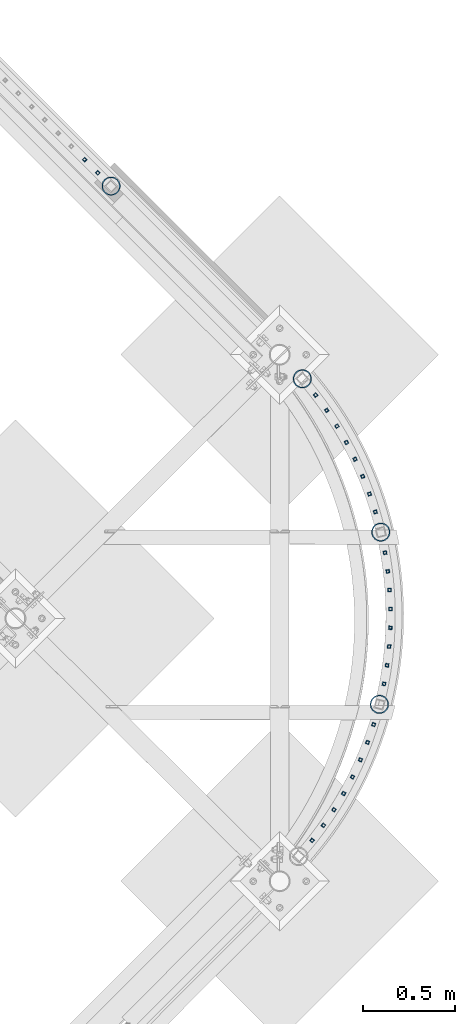
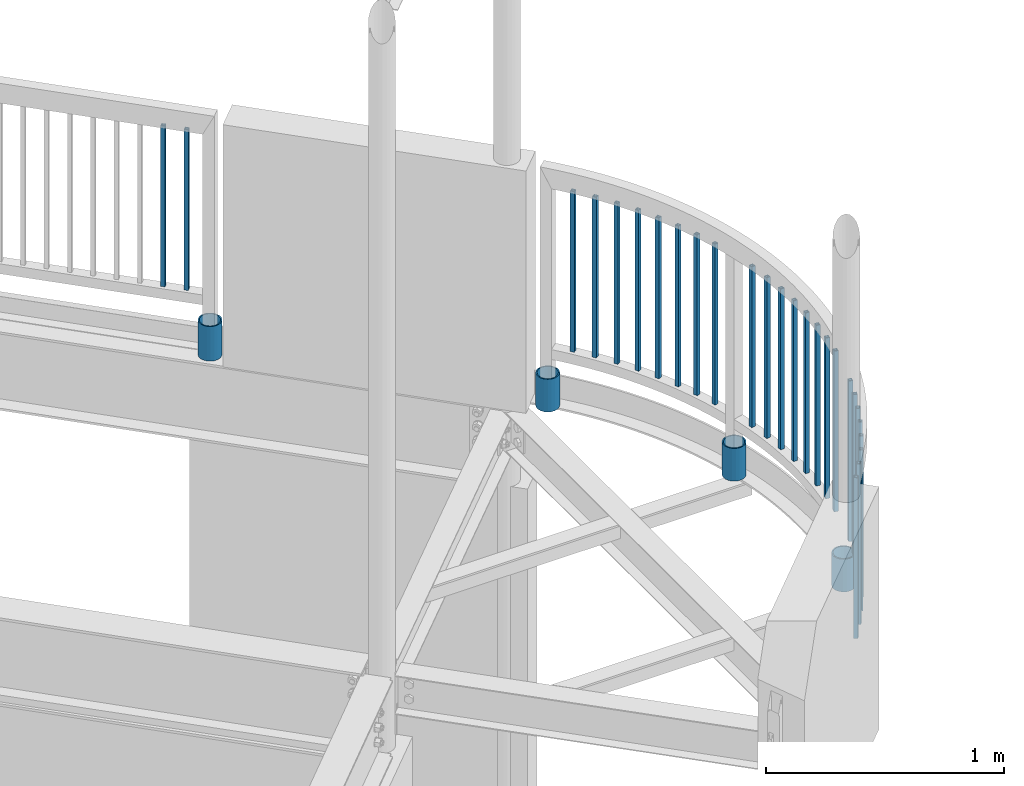
# One storey, part 277 of 975: 30 columns.
"""IFC2X3 building model written with IfcOpenShell, lengths in millimetres."""

from ifc_helpers import new_model, si_unit, frame, origin_with_axes, place, context, subcontext, project, spatial, faceted_brep, material, type_object, element, save


model = new_model("IFC2X3")

# Units and contexts
model_context = context("Model", 3, precision=1e-05, world=origin_with_axes())
body_context = subcontext(model_context, "Body", "Model", "MODEL_VIEW")
ifc_project = project(units=[si_unit("LENGTHUNIT", "METRE", prefix="MILLI"), si_unit("AREAUNIT", "SQUARE_METRE"), si_unit("VOLUMEUNIT", "CUBIC_METRE"), si_unit("MASSUNIT", "GRAM", prefix="KILO"), si_unit("TIMEUNIT", "SECOND"), si_unit("PLANEANGLEUNIT", "RADIAN"), si_unit("SOLIDANGLEUNIT", "STERADIAN"), si_unit("THERMODYNAMICTEMPERATUREUNIT", "DEGREE_CELSIUS"), si_unit("LUMINOUSINTENSITYUNIT", "LUMEN")], contexts=[model_context])

# Site, building, storey
site_placement = place(None, origin_with_axes())
site = spatial("IfcSite", under=ifc_project, at=site_placement, CompositionType="ELEMENT")
building_placement = place(site_placement, origin_with_axes())
building = spatial("IfcBuilding", under=site, at=building_placement, Name="Undefined", CompositionType="ELEMENT")
storey_placement = place(building_placement, origin_with_axes())
storey = spatial("IfcBuildingStorey", under=building, at=storey_placement, Name="Undefined", CompositionType="ELEMENT", Elevation=0.0)

# Columns
ifc_material_1 = material()
column_type_1 = type_object("IfcColumnType", Name="HSS3/4X3/4X.120_TUBES", PredefinedType="NOTDEFINED")
for number, where, z_axis, x_axis, name in (
    (1, (36056.6912059696, 12244.4893674589, 4254.49994796637), (-0.283882476097402, 0.958859082328998, -1.36006965476554e-08), (0.0, 0.0, 1.0), "PICKET"),
    (2, (35732.4870797889, 12877.9863255874, 4254.49994796637), (-0.607293483116321, 0.794477580152169, -1.34104184326134e-08), (0.0, 0.0, 1.0), "PICKET"),
    (3, (35792.6550644485, 12795.3541853441, 4254.49994796637), (-0.56508307472927, 0.825034010604723, -1.3596040844277e-08), (0.0, 0.0, 1.0), "PICKET"),
    (4, (35848.4368898386, 12709.6999680789, 4254.49994796637), (-0.521338232018431, 0.853350132030163, -1.44109080792987e-08), (0.0, 0.0, 1.0), "PICKET"),
    (5, (35899.681085213, 12621.2562604475, 4254.49994796637), (-0.476177741822168, 0.879349053671601, -1.38854329634341e-08), (0.0, 0.0, 1.0), "PICKET"),
    (6, (35946.2485013691, 12530.2632237265, 4254.49994796637), (-0.429724229889405, 0.902960179767612, -1.34138672365225e-08), (0.0, 0.0, 1.0), "PICKET"),
    (7, (35988.0126884958, 12436.9679416766, 4254.49994796637), (-0.382103840208313, 0.924119394503794, -1.43061743074213e-08), (0.0, 0.0, 1.0), "PICKET"),
    (8, (36024.8602395373, 12341.6237496071, 4254.49994796637), (-0.333445879927349, 0.942769242794585, -1.29804593598237e-08), (0.0, 0.0, 1.0), "PICKET"),
    (9, (36103.5076687763, 11311.4462285557, 4254.49994796637), (0.191835812975776, 0.981427032876068, -1.31422229969758e-08), (0.0, 0.0, 1.0), "PICKET"),
    (10, (36109.0972812196, 12023.0609189764, 4254.49994796637), (-0.170932835042666, 0.985282683245918, -1.33214734887588e-08), (0.0, 0.0, 1.0), "PICKET"),
    (11, (36124.2199175269, 11921.9690654457, 4254.49994796637), (-0.119375467966675, 0.992849181722852, -1.31457900351961e-08), (0.0, 0.0, 1.0), "PICKET"),
    (12, (36134.0559506074, 11820.2266975139, 4254.49994796637), (-0.0674939469756137, 0.997719683639474, -1.40355705298134e-08), (0.0, 0.0, 1.0), "PICKET"),
    (13, (36138.5786715598, 11718.1100878252, 4254.49994796637), (-0.0154291539925689, 0.999880963518695, -1.4013763575349e-08), (0.0, 0.0, 1.0), "PICKET"),
    (14, (36137.7757993245, 11615.8965252451, 4254.49994796637), (0.036677537990523, 0.99932715274176, -1.29912523334497e-08), (0.0, 0.0, 1.0), "PICKET"),
    (15, (36131.6495140321, 11513.8635619066, 4254.49994796637), (0.0886846340071643, 0.996059755080495, -1.40335214382503e-08), (0.0, 0.0, 1.0), "PICKET"),
    (16, (36120.216451083, 11412.2882595406, 4254.49994796637), (0.140450914975729, 0.990087642828896, -1.3011589544476e-08), (0.0, 0.0, 1.0), "PICKET"),
    (17, (35713.4324205708, 10462.563089986, 4254.49994796637), (0.624042439778597, 0.781390448722773, -1.35876362037379e-08), (0.0, 0.0, 1.0), "PICKET"),
    (18, (36047.5479517224, 11090.8890589191, 4254.49994796637), (0.304198321977405, 0.952608723929259, -1.32965087686898e-08), (0.0, 0.0, 1.0), "PICKET"),
    (19, (36014.1951655572, 10994.2668635693, 4254.49994796637), (0.353408549827145, 0.935469078542457, -1.35747304739198e-08), (0.0, 0.0, 1.0), "PICKET"),
    (20, (35975.8544247656, 10899.5132642987, 4254.49994796637), (0.401659127155996, 0.91578924735568, -1.3913554539613e-08), (0.0, 0.0, 1.0), "PICKET"),
    (21, (35932.6298403295, 10806.8855563517, 4254.49994796637), (0.448819032838204, 0.893622669677856, -1.43100078275893e-08), (0.0, 0.0, 1.0), "PICKET"),
    (22, (35884.6387848882, 10716.6352622978, 4254.49994796637), (0.494760210039676, 0.869029536069687, -1.33969151647761e-08), (0.0, 0.0, 1.0), "PICKET"),
    (23, (35832.0115740227, 10629.0074490436, 4254.49994796637), (0.539357907906692, 0.842076627854328, -1.38804252856062e-08), (0.0, 0.0, 1.0), "PICKET"),
    (24, (35774.891112395, 10544.240062375, 4254.49994796637), (0.582491025955096, 0.812837132937331, -1.30186463138671e-08), (0.0, 0.0, 1.0), "PICKET"),
    (25, (34479.1391914805, 14155.1566726498, 4254.49994796637), (-0.707106781186601, 0.707106781186494, 2.36468622460961e-14), (0.0, 0.0, 1.0), "PICKET"),
    (26, (34550.9735664805, 14083.3222976498, 4254.49994796637), (-0.707106781186601, 0.707106781186494, 2.36468622460961e-14), (0.0, 0.0, 1.0), "PICKET"),
):
    element("IfcColumn", number, at=place(storey_placement, frame(where, z_axis=z_axis, x_axis=x_axis)), inside=storey, type_object=column_type_1, material=ifc_material_1, Name=name, ObjectType="HSS3/4X3/4X.120_TUBES", context=body_context, shape_type="Brep", body=[
        faceted_brep([(0.0, 6.34999999998763, -6.34999999998763), (0.0, -6.35000000000582, -6.34999999998763), (825.49997943247, -6.35000000000582, -6.34999999998763), (825.49997943247, 6.34999999998763, -6.34999999998763), (0.0, -6.34999999998763, 6.34999999998763), (825.49997943247, -6.34999999998763, 6.34999999998763), (0.0, 6.35000000000946, 6.34999999998763), (825.49997943247, 6.35000000000946, 6.34999999998763), (0.0, 9.52499999997963, -9.52499999997963), (0.0, 9.52500000000873, 9.5249999999869), (825.49997943247, 9.52500000000873, 9.5249999999869), (825.49997943247, 9.52499999997963, -9.52499999997963), (0.0, -9.52499999997963, 9.52499999998327), (825.49997943247, -9.52499999997963, 9.52499999998327), (0.0, -9.52500000000873, -9.5249999999869), (825.49997943247, -9.52500000000873, -9.5249999999869)], [[[0, 1, 2, 3]], [[1, 4, 5, 2]], [[4, 6, 7, 5]], [[6, 0, 3, 7]], [[8, 9, 10, 11]], [[9, 12, 13, 10]], [[12, 14, 15, 13]], [[14, 8, 11, 15]], [[13, 15, 11, 10], [5, 7, 3, 2]], [[14, 12, 9, 8], [6, 4, 1, 0]]]),
    ])
ifc_material_2 = material(Name="STEEL/A53")
column_type_2 = type_object("IfcColumnType", Name="PIPE3-1/2STD", PredefinedType="NOTDEFINED")
column_1_placement = place(storey_placement, frame((36078.7761034097, 11200.4077223262, 3946.52499999334), z_axis=(0.969531343145851, -0.244967293036851, 0.0), x_axis=(0.0, 0.0, 1.0)))
element("IfcColumn", 27, at=column_1_placement, inside=storey, type_object=column_type_2, material=ifc_material_2, ObjectType="PIPE3-1/2STD", context=body_context, shape_type="Brep", body=[
    faceted_brep([(0.0, -45.0595999999932, 1.45519152283669e-11), (0.0, -42.8542262016344, 13.924182159768), (168.275, -42.8542262015544, 13.9241821597034), (168.275, -45.0595999998914, 2.72848410531878e-12), (0.0, -36.45398215971, 26.4853683542424), (168.275, -36.4539821596554, 26.485368354136), (0.0, -26.4853683541623, 36.45398215979), (168.275, -26.4853683541369, 36.4539821596509), (0.0, -13.9241821596988, 42.8542262017108), (168.275, -13.9241821597025, 42.8542262015517), (0.0, 3.63797880709171e-11, 45.0596000000514), (168.275, 0.0, 45.0595999998905), (0.0, 13.9241821597716, 42.8542262017036), (168.275, 13.9241821597025, 42.8542262015517), (0.0, 26.4853683542242, 36.4539821597718), (168.275, 26.4853683541296, 36.4539821596509), (0.0, 36.4539821597537, 26.4853683542206), (168.275, 36.4539821596481, 26.4853683541342), (0.0, 42.8542262016563, 13.9241821597425), (168.275, 42.8542262015471, 13.9241821597034), (0.0, 45.0595999999932, -1.09139364212751e-11), (168.275, 45.0595999998914, -9.09494701772928e-13), (0.0, 42.8542262016344, -13.9241821597643), (168.275, 42.8542262015471, -13.9241821596997), (0.0, 36.45398215971, -26.4853683542387), (168.275, 36.4539821596481, -26.4853683541323), (0.0, 26.4853683541623, -36.4539821597864), (168.275, 26.4853683541296, -36.4539821596472), (0.0, 13.9241821596988, -42.8542262017072), (168.275, 13.9241821596952, -42.854226201548), (0.0, -3.63797880709171e-11, -45.0596000000478), (168.275, 0.0, -45.0595999998886), (0.0, -13.9241821597716, -42.8542262016963), (168.275, -13.9241821597025, -42.8542262015499), (0.0, -26.4853683542242, -36.4539821597682), (168.275, -26.4853683541369, -36.4539821596472), (0.0, -36.4539821597537, -26.4853683542169), (168.275, -36.4539821596554, -26.4853683541305), (0.0, -42.8542262016563, -13.9241821597352), (168.275, -42.8542262015544, -13.9241821597016), (0.0, -50.799999999992, 1.81898940354586e-11), (0.0, -48.3136710278013, -15.6980633142484), (168.275, -48.3136710276813, -15.6980633142075), (168.275, -50.7999999998792, 9.09494701772928e-13), (0.0, -41.0980633142644, -29.8594908164741), (168.275, -41.0980633141517, -29.8594908163841), (0.0, -29.859490816485, -41.0980633142826), (168.275, -29.8594908163868, -41.0980633141471), (0.0, -15.6980633142848, -48.313671027845), (168.275, -15.6980633142084, -48.3136710276767), (0.0, -4.36557456851006e-11, -50.8000000000575), (168.275, 0.0, -50.7999999998747), (0.0, 15.6980633142011, -48.3136710278523), (168.275, 15.6980633142084, -48.3136710276749), (0.0, 29.8594908164159, -41.0980633143045), (168.275, 29.8594908163868, -41.0980633141471), (0.0, 41.0980633142135, -29.8594908165032), (168.275, 41.0980633141444, -29.8594908163859), (0.0, 48.3136710277722, -15.6980633142775), (168.275, 48.313671027674, -15.6980633142057), (0.0, 50.799999999992, -1.45519152283669e-11), (168.275, 50.7999999998719, 9.09494701772928e-13), (0.0, 48.313671027794, 15.6980633142521), (168.275, 48.313671027674, 15.6980633142093), (0.0, 41.0980633142644, 29.8594908164814), (168.275, 41.0980633141444, 29.8594908163877), (0.0, 29.859490816485, 41.0980633142863), (168.275, 29.8594908163795, 41.0980633141507), (0.0, 15.6980633142848, 48.3136710278486), (168.275, 15.6980633142084, 48.3136710276785), (0.0, 4.00177668780088e-11, 50.8000000000611), (168.275, 0.0, 50.7999999998765), (0.0, -15.6980633142011, 48.3136710278559), (168.275, -15.6980633142084, 48.3136710276785), (0.0, -29.8594908164159, 41.0980633143081), (168.275, -29.8594908163941, 41.0980633141507), (0.0, -41.0980633142171, 29.8594908165069), (168.275, -41.0980633141517, 29.8594908163896), (0.0, -48.3136710277722, 15.6980633142812), (168.275, -48.3136710276813, 15.6980633142093)], [[[0, 1, 2, 3]], [[1, 4, 5, 2]], [[4, 6, 7, 5]], [[6, 8, 9, 7]], [[8, 10, 11, 9]], [[10, 12, 13, 11]], [[12, 14, 15, 13]], [[14, 16, 17, 15]], [[16, 18, 19, 17]], [[18, 20, 21, 19]], [[20, 22, 23, 21]], [[22, 24, 25, 23]], [[24, 26, 27, 25]], [[26, 28, 29, 27]], [[28, 30, 31, 29]], [[30, 32, 33, 31]], [[32, 34, 35, 33]], [[34, 36, 37, 35]], [[36, 38, 39, 37]], [[38, 0, 3, 39]], [[40, 41, 42, 43]], [[41, 44, 45, 42]], [[44, 46, 47, 45]], [[46, 48, 49, 47]], [[48, 50, 51, 49]], [[50, 52, 53, 51]], [[52, 54, 55, 53]], [[54, 56, 57, 55]], [[56, 58, 59, 57]], [[58, 60, 61, 59]], [[60, 62, 63, 61]], [[62, 64, 65, 63]], [[64, 66, 67, 65]], [[66, 68, 69, 67]], [[68, 70, 71, 69]], [[70, 72, 73, 71]], [[72, 74, 75, 73]], [[74, 76, 77, 75]], [[76, 78, 79, 77]], [[78, 40, 43, 79]], [[45, 47, 49, 51, 53, 55, 57, 59, 61, 63, 65, 67, 69, 71, 73, 75, 77, 79, 43, 42], [5, 7, 9, 11, 13, 15, 17, 19, 21, 23, 25, 27, 29, 31, 33, 35, 37, 39, 3, 2]], [[78, 76, 74, 72, 70, 68, 66, 64, 62, 60, 58, 56, 54, 52, 50, 48, 46, 44, 41, 40], [38, 36, 34, 32, 30, 28, 26, 24, 22, 20, 18, 16, 14, 12, 10, 8, 6, 4, 1, 0]]]),
])
column_2_placement = place(storey_placement, frame((36086.125656387, 12134.6039135276, 3946.52499999334), z_axis=(0.968966441574155, 0.247192303891364, 0.0), x_axis=(0.0, 0.0, 1.0)))
element("IfcColumn", 28, at=column_2_placement, inside=storey, type_object=column_type_2, material=ifc_material_2, ObjectType="PIPE3-1/2STD", context=body_context, shape_type="Brep", body=[
    faceted_brep([(0.0, -45.0595999999932, 1.45519152283669e-11), (0.0, -42.8542262016344, 13.924182159768), (168.275, -42.8542262015544, 13.9241821597034), (168.275, -45.0595999998914, 2.72848410531878e-12), (0.0, -36.45398215971, 26.4853683542424), (168.275, -36.4539821596554, 26.485368354136), (0.0, -26.4853683541623, 36.45398215979), (168.275, -26.4853683541369, 36.4539821596509), (0.0, -13.9241821596988, 42.8542262017108), (168.275, -13.9241821597025, 42.8542262015517), (0.0, 3.63797880709171e-11, 45.0596000000514), (168.275, 0.0, 45.0595999998905), (0.0, 13.9241821597716, 42.8542262017036), (168.275, 13.9241821597025, 42.8542262015517), (0.0, 26.4853683542242, 36.4539821597718), (168.275, 26.4853683541296, 36.4539821596509), (0.0, 36.4539821597537, 26.4853683542206), (168.275, 36.4539821596481, 26.4853683541342), (0.0, 42.8542262016563, 13.9241821597425), (168.275, 42.8542262015471, 13.9241821597034), (0.0, 45.0595999999932, -1.09139364212751e-11), (168.275, 45.0595999998914, -9.09494701772928e-13), (0.0, 42.8542262016344, -13.9241821597643), (168.275, 42.8542262015471, -13.9241821596997), (0.0, 36.45398215971, -26.4853683542387), (168.275, 36.4539821596481, -26.4853683541323), (0.0, 26.4853683541623, -36.4539821597864), (168.275, 26.4853683541296, -36.4539821596472), (0.0, 13.9241821596988, -42.8542262017072), (168.275, 13.9241821596952, -42.854226201548), (0.0, -3.63797880709171e-11, -45.0596000000478), (168.275, 0.0, -45.0595999998886), (0.0, -13.9241821597716, -42.8542262016963), (168.275, -13.9241821597025, -42.8542262015499), (0.0, -26.4853683542242, -36.4539821597682), (168.275, -26.4853683541369, -36.4539821596472), (0.0, -36.4539821597537, -26.4853683542169), (168.275, -36.4539821596554, -26.4853683541305), (0.0, -42.8542262016563, -13.9241821597352), (168.275, -42.8542262015544, -13.9241821597016), (0.0, -50.799999999992, 1.81898940354586e-11), (0.0, -48.3136710278013, -15.6980633142484), (168.275, -48.3136710276813, -15.6980633142075), (168.275, -50.7999999998792, 9.09494701772928e-13), (0.0, -41.0980633142644, -29.8594908164741), (168.275, -41.0980633141517, -29.8594908163841), (0.0, -29.859490816485, -41.0980633142826), (168.275, -29.8594908163868, -41.0980633141471), (0.0, -15.6980633142848, -48.313671027845), (168.275, -15.6980633142084, -48.3136710276767), (0.0, -4.36557456851006e-11, -50.8000000000575), (168.275, 0.0, -50.7999999998747), (0.0, 15.6980633142011, -48.3136710278523), (168.275, 15.6980633142084, -48.3136710276749), (0.0, 29.8594908164159, -41.0980633143045), (168.275, 29.8594908163868, -41.0980633141471), (0.0, 41.0980633142135, -29.8594908165032), (168.275, 41.0980633141444, -29.8594908163859), (0.0, 48.3136710277722, -15.6980633142775), (168.275, 48.313671027674, -15.6980633142057), (0.0, 50.799999999992, -1.45519152283669e-11), (168.275, 50.7999999998719, 9.09494701772928e-13), (0.0, 48.313671027794, 15.6980633142521), (168.275, 48.313671027674, 15.6980633142093), (0.0, 41.0980633142644, 29.8594908164814), (168.275, 41.0980633141444, 29.8594908163877), (0.0, 29.859490816485, 41.0980633142863), (168.275, 29.8594908163795, 41.0980633141507), (0.0, 15.6980633142848, 48.3136710278486), (168.275, 15.6980633142084, 48.3136710276785), (0.0, 4.00177668780088e-11, 50.8000000000611), (168.275, 0.0, 50.7999999998765), (0.0, -15.6980633142011, 48.3136710278559), (168.275, -15.6980633142084, 48.3136710276785), (0.0, -29.8594908164159, 41.0980633143081), (168.275, -29.8594908163941, 41.0980633141507), (0.0, -41.0980633142171, 29.8594908165069), (168.275, -41.0980633141517, 29.8594908163896), (0.0, -48.3136710277722, 15.6980633142812), (168.275, -48.3136710276813, 15.6980633142093)], [[[0, 1, 2, 3]], [[1, 4, 5, 2]], [[4, 6, 7, 5]], [[6, 8, 9, 7]], [[8, 10, 11, 9]], [[10, 12, 13, 11]], [[12, 14, 15, 13]], [[14, 16, 17, 15]], [[16, 18, 19, 17]], [[18, 20, 21, 19]], [[20, 22, 23, 21]], [[22, 24, 25, 23]], [[24, 26, 27, 25]], [[26, 28, 29, 27]], [[28, 30, 31, 29]], [[30, 32, 33, 31]], [[32, 34, 35, 33]], [[34, 36, 37, 35]], [[36, 38, 39, 37]], [[38, 0, 3, 39]], [[40, 41, 42, 43]], [[41, 44, 45, 42]], [[44, 46, 47, 45]], [[46, 48, 49, 47]], [[48, 50, 51, 49]], [[50, 52, 53, 51]], [[52, 54, 55, 53]], [[54, 56, 57, 55]], [[56, 58, 59, 57]], [[58, 60, 61, 59]], [[60, 62, 63, 61]], [[62, 64, 65, 63]], [[64, 66, 67, 65]], [[66, 68, 69, 67]], [[68, 70, 71, 69]], [[70, 72, 73, 71]], [[72, 74, 75, 73]], [[74, 76, 77, 75]], [[76, 78, 79, 77]], [[78, 40, 43, 79]], [[45, 47, 49, 51, 53, 55, 57, 59, 61, 63, 65, 67, 69, 71, 73, 75, 77, 79, 43, 42], [5, 7, 9, 11, 13, 15, 17, 19, 21, 23, 25, 27, 29, 31, 33, 35, 37, 39, 3, 2]], [[78, 76, 74, 72, 70, 68, 66, 64, 62, 60, 58, 56, 54, 52, 50, 48, 46, 44, 41, 40], [38, 36, 34, 32, 30, 28, 26, 24, 22, 20, 18, 16, 14, 12, 10, 8, 6, 4, 1, 0]]]),
])
column_3_placement = place(storey_placement, frame((35660.5273593798, 12966.2522543199, 3946.52499999334), z_axis=(0.733697144241169, 0.679476637223351, 0.0), x_axis=(0.0, 0.0, 1.0)))
element("IfcColumn", 29, at=column_3_placement, inside=storey, type_object=column_type_2, material=ifc_material_2, ObjectType="PIPE3-1/2STD", context=body_context, shape_type="Brep", body=[
    faceted_brep([(0.0, -45.0595999999932, 1.45519152283669e-11), (0.0, -42.8542262016344, 13.924182159768), (168.275, -42.8542262015544, 13.9241821597034), (168.275, -45.0595999998914, 2.72848410531878e-12), (0.0, -36.45398215971, 26.4853683542424), (168.275, -36.4539821596554, 26.485368354136), (0.0, -26.4853683541623, 36.45398215979), (168.275, -26.4853683541369, 36.4539821596509), (0.0, -13.9241821596988, 42.8542262017108), (168.275, -13.9241821597025, 42.8542262015517), (0.0, 3.63797880709171e-11, 45.0596000000514), (168.275, 0.0, 45.0595999998905), (0.0, 13.9241821597716, 42.8542262017036), (168.275, 13.9241821597025, 42.8542262015517), (0.0, 26.4853683542242, 36.4539821597718), (168.275, 26.4853683541296, 36.4539821596509), (0.0, 36.4539821597537, 26.4853683542206), (168.275, 36.4539821596481, 26.4853683541342), (0.0, 42.8542262016563, 13.9241821597425), (168.275, 42.8542262015471, 13.9241821597034), (0.0, 45.0595999999932, -1.09139364212751e-11), (168.275, 45.0595999998914, -9.09494701772928e-13), (0.0, 42.8542262016344, -13.9241821597643), (168.275, 42.8542262015471, -13.9241821596997), (0.0, 36.45398215971, -26.4853683542387), (168.275, 36.4539821596481, -26.4853683541323), (0.0, 26.4853683541623, -36.4539821597864), (168.275, 26.4853683541296, -36.4539821596472), (0.0, 13.9241821596988, -42.8542262017072), (168.275, 13.9241821596952, -42.854226201548), (0.0, -3.63797880709171e-11, -45.0596000000478), (168.275, 0.0, -45.0595999998886), (0.0, -13.9241821597716, -42.8542262016963), (168.275, -13.9241821597025, -42.8542262015499), (0.0, -26.4853683542242, -36.4539821597682), (168.275, -26.4853683541369, -36.4539821596472), (0.0, -36.4539821597537, -26.4853683542169), (168.275, -36.4539821596554, -26.4853683541305), (0.0, -42.8542262016563, -13.9241821597352), (168.275, -42.8542262015544, -13.9241821597016), (0.0, -50.799999999992, 1.81898940354586e-11), (0.0, -48.3136710278013, -15.6980633142484), (168.275, -48.3136710276813, -15.6980633142075), (168.275, -50.7999999998792, 9.09494701772928e-13), (0.0, -41.0980633142644, -29.8594908164741), (168.275, -41.0980633141517, -29.8594908163841), (0.0, -29.859490816485, -41.0980633142826), (168.275, -29.8594908163868, -41.0980633141471), (0.0, -15.6980633142848, -48.313671027845), (168.275, -15.6980633142084, -48.3136710276767), (0.0, -4.36557456851006e-11, -50.8000000000575), (168.275, 0.0, -50.7999999998747), (0.0, 15.6980633142011, -48.3136710278523), (168.275, 15.6980633142084, -48.3136710276749), (0.0, 29.8594908164159, -41.0980633143045), (168.275, 29.8594908163868, -41.0980633141471), (0.0, 41.0980633142135, -29.8594908165032), (168.275, 41.0980633141444, -29.8594908163859), (0.0, 48.3136710277722, -15.6980633142775), (168.275, 48.313671027674, -15.6980633142057), (0.0, 50.799999999992, -1.45519152283669e-11), (168.275, 50.7999999998719, 9.09494701772928e-13), (0.0, 48.313671027794, 15.6980633142521), (168.275, 48.313671027674, 15.6980633142093), (0.0, 41.0980633142644, 29.8594908164814), (168.275, 41.0980633141444, 29.8594908163877), (0.0, 29.859490816485, 41.0980633142863), (168.275, 29.8594908163795, 41.0980633141507), (0.0, 15.6980633142848, 48.3136710278486), (168.275, 15.6980633142084, 48.3136710276785), (0.0, 4.00177668780088e-11, 50.8000000000611), (168.275, 0.0, 50.7999999998765), (0.0, -15.6980633142011, 48.3136710278559), (168.275, -15.6980633142084, 48.3136710276785), (0.0, -29.8594908164159, 41.0980633143081), (168.275, -29.8594908163941, 41.0980633141507), (0.0, -41.0980633142171, 29.8594908165069), (168.275, -41.0980633141517, 29.8594908163896), (0.0, -48.3136710277722, 15.6980633142812), (168.275, -48.3136710276813, 15.6980633142093)], [[[0, 1, 2, 3]], [[1, 4, 5, 2]], [[4, 6, 7, 5]], [[6, 8, 9, 7]], [[8, 10, 11, 9]], [[10, 12, 13, 11]], [[12, 14, 15, 13]], [[14, 16, 17, 15]], [[16, 18, 19, 17]], [[18, 20, 21, 19]], [[20, 22, 23, 21]], [[22, 24, 25, 23]], [[24, 26, 27, 25]], [[26, 28, 29, 27]], [[28, 30, 31, 29]], [[30, 32, 33, 31]], [[32, 34, 35, 33]], [[34, 36, 37, 35]], [[36, 38, 39, 37]], [[38, 0, 3, 39]], [[40, 41, 42, 43]], [[41, 44, 45, 42]], [[44, 46, 47, 45]], [[46, 48, 49, 47]], [[48, 50, 51, 49]], [[50, 52, 53, 51]], [[52, 54, 55, 53]], [[54, 56, 57, 55]], [[56, 58, 59, 57]], [[58, 60, 61, 59]], [[60, 62, 63, 61]], [[62, 64, 65, 63]], [[64, 66, 67, 65]], [[66, 68, 69, 67]], [[68, 70, 71, 69]], [[70, 72, 73, 71]], [[72, 74, 75, 73]], [[74, 76, 77, 75]], [[76, 78, 79, 77]], [[78, 40, 43, 79]], [[45, 47, 49, 51, 53, 55, 57, 59, 61, 63, 65, 67, 69, 71, 73, 75, 77, 79, 43, 42], [5, 7, 9, 11, 13, 15, 17, 19, 21, 23, 25, 27, 29, 31, 33, 35, 37, 39, 3, 2]], [[78, 76, 74, 72, 70, 68, 66, 64, 62, 60, 58, 56, 54, 52, 50, 48, 46, 44, 41, 40], [38, 36, 34, 32, 30, 28, 26, 24, 22, 20, 18, 16, 14, 12, 10, 8, 6, 4, 1, 0]]]),
])
column_4_placement = place(storey_placement, frame((34622.951391719, 14011.6986054537, 3937.0), z_axis=(-0.707106781186601, 0.707106781186494, 2.36468622460961e-14), x_axis=(0.0, 0.0, 1.0)))
element("IfcColumn", 30, at=column_4_placement, inside=storey, type_object=column_type_2, material=ifc_material_2, ObjectType="PIPE3-1/2STD", context=body_context, shape_type="Brep", body=[
    faceted_brep([(0.0, -45.0595999999932, 1.45519152283669e-11), (0.0, -42.8542262016344, 13.924182159768), (177.8, -42.8542262016344, 13.924182159768), (177.8, -45.0595999999932, 1.45519152283669e-11), (0.0, -36.45398215971, 26.4853683542424), (177.8, -36.45398215971, 26.4853683542424), (0.0, -26.4853683541623, 36.45398215979), (177.8, -26.4853683541623, 36.45398215979), (0.0, -13.9241821596988, 42.8542262017108), (177.8, -13.9241821596988, 42.8542262017108), (0.0, 3.63797880709171e-11, 45.0596000000514), (177.8, 3.63797880709171e-11, 45.0596000000514), (0.0, 13.9241821597716, 42.8542262017036), (177.8, 13.9241821597716, 42.8542262017036), (0.0, 26.4853683542242, 36.4539821597718), (177.8, 26.4853683542242, 36.4539821597718), (0.0, 36.4539821597537, 26.4853683542206), (177.8, 36.4539821597537, 26.4853683542206), (0.0, 42.8542262016563, 13.9241821597425), (177.8, 42.8542262016563, 13.9241821597425), (0.0, 45.0595999999932, -1.09139364212751e-11), (177.8, 45.0595999999932, -1.09139364212751e-11), (0.0, 42.8542262016344, -13.9241821597643), (177.8, 42.8542262016344, -13.9241821597643), (0.0, 36.45398215971, -26.4853683542387), (177.8, 36.45398215971, -26.4853683542387), (0.0, 26.4853683541623, -36.4539821597864), (177.8, 26.4853683541623, -36.4539821597864), (0.0, 13.9241821596988, -42.8542262017072), (177.8, 13.9241821596988, -42.8542262017072), (0.0, -3.63797880709171e-11, -45.0596000000478), (177.8, -3.63797880709171e-11, -45.0596000000478), (0.0, -13.9241821597716, -42.8542262016963), (177.8, -13.9241821597716, -42.8542262016963), (0.0, -26.4853683542242, -36.4539821597682), (177.8, -26.4853683542242, -36.4539821597682), (0.0, -36.4539821597537, -26.4853683542169), (177.8, -36.4539821597537, -26.4853683542169), (0.0, -42.8542262016563, -13.9241821597352), (177.8, -42.8542262016563, -13.9241821597352), (0.0, -50.799999999992, 1.81898940354586e-11), (0.0, -48.3136710278013, -15.6980633142484), (177.8, -48.3136710278013, -15.6980633142484), (177.8, -50.799999999992, 1.81898940354586e-11), (0.0, -41.0980633142644, -29.8594908164741), (177.8, -41.0980633142644, -29.8594908164741), (0.0, -29.859490816485, -41.0980633142826), (177.8, -29.859490816485, -41.0980633142826), (0.0, -15.6980633142848, -48.313671027845), (177.8, -15.6980633142848, -48.313671027845), (0.0, -4.36557456851006e-11, -50.8000000000575), (177.8, -4.36557456851006e-11, -50.8000000000575), (0.0, 15.6980633142011, -48.3136710278523), (177.8, 15.6980633142011, -48.3136710278523), (0.0, 29.8594908164159, -41.0980633143045), (177.8, 29.8594908164159, -41.0980633143045), (0.0, 41.0980633142135, -29.8594908165032), (177.8, 41.0980633142135, -29.8594908165032), (0.0, 48.3136710277722, -15.6980633142775), (177.8, 48.3136710277722, -15.6980633142775), (0.0, 50.799999999992, -1.45519152283669e-11), (177.8, 50.799999999992, -1.45519152283669e-11), (0.0, 48.313671027794, 15.6980633142521), (177.8, 48.313671027794, 15.6980633142521), (0.0, 41.0980633142644, 29.8594908164814), (177.8, 41.0980633142644, 29.8594908164814), (0.0, 29.859490816485, 41.0980633142863), (177.8, 29.859490816485, 41.0980633142863), (0.0, 15.6980633142848, 48.3136710278486), (177.8, 15.6980633142848, 48.3136710278486), (0.0, 4.00177668780088e-11, 50.8000000000611), (177.8, 4.00177668780088e-11, 50.8000000000611), (0.0, -15.6980633142011, 48.3136710278559), (177.8, -15.6980633142011, 48.3136710278559), (0.0, -29.8594908164159, 41.0980633143081), (177.8, -29.8594908164159, 41.0980633143081), (0.0, -41.0980633142171, 29.8594908165069), (177.8, -41.0980633142171, 29.8594908165069), (0.0, -48.3136710277722, 15.6980633142812), (177.8, -48.3136710277722, 15.6980633142812)], [[[0, 1, 2, 3]], [[1, 4, 5, 2]], [[4, 6, 7, 5]], [[6, 8, 9, 7]], [[8, 10, 11, 9]], [[10, 12, 13, 11]], [[12, 14, 15, 13]], [[14, 16, 17, 15]], [[16, 18, 19, 17]], [[18, 20, 21, 19]], [[20, 22, 23, 21]], [[22, 24, 25, 23]], [[24, 26, 27, 25]], [[26, 28, 29, 27]], [[28, 30, 31, 29]], [[30, 32, 33, 31]], [[32, 34, 35, 33]], [[34, 36, 37, 35]], [[36, 38, 39, 37]], [[38, 0, 3, 39]], [[40, 41, 42, 43]], [[41, 44, 45, 42]], [[44, 46, 47, 45]], [[46, 48, 49, 47]], [[48, 50, 51, 49]], [[50, 52, 53, 51]], [[52, 54, 55, 53]], [[54, 56, 57, 55]], [[56, 58, 59, 57]], [[58, 60, 61, 59]], [[60, 62, 63, 61]], [[62, 64, 65, 63]], [[64, 66, 67, 65]], [[66, 68, 69, 67]], [[68, 70, 71, 69]], [[70, 72, 73, 71]], [[72, 74, 75, 73]], [[74, 76, 77, 75]], [[76, 78, 79, 77]], [[78, 40, 43, 79]], [[45, 47, 49, 51, 53, 55, 57, 59, 61, 63, 65, 67, 69, 71, 73, 75, 77, 79, 43, 42], [5, 7, 9, 11, 13, 15, 17, 19, 21, 23, 25, 27, 29, 31, 33, 35, 37, 39, 3, 2]], [[78, 76, 74, 72, 70, 68, 66, 64, 62, 60, 58, 56, 54, 52, 50, 48, 46, 44, 41, 40], [38, 36, 34, 32, 30, 28, 26, 24, 22, 20, 18, 16, 14, 12, 10, 8, 6, 4, 1, 0]]]),
])

save(model, "model.ifc")
